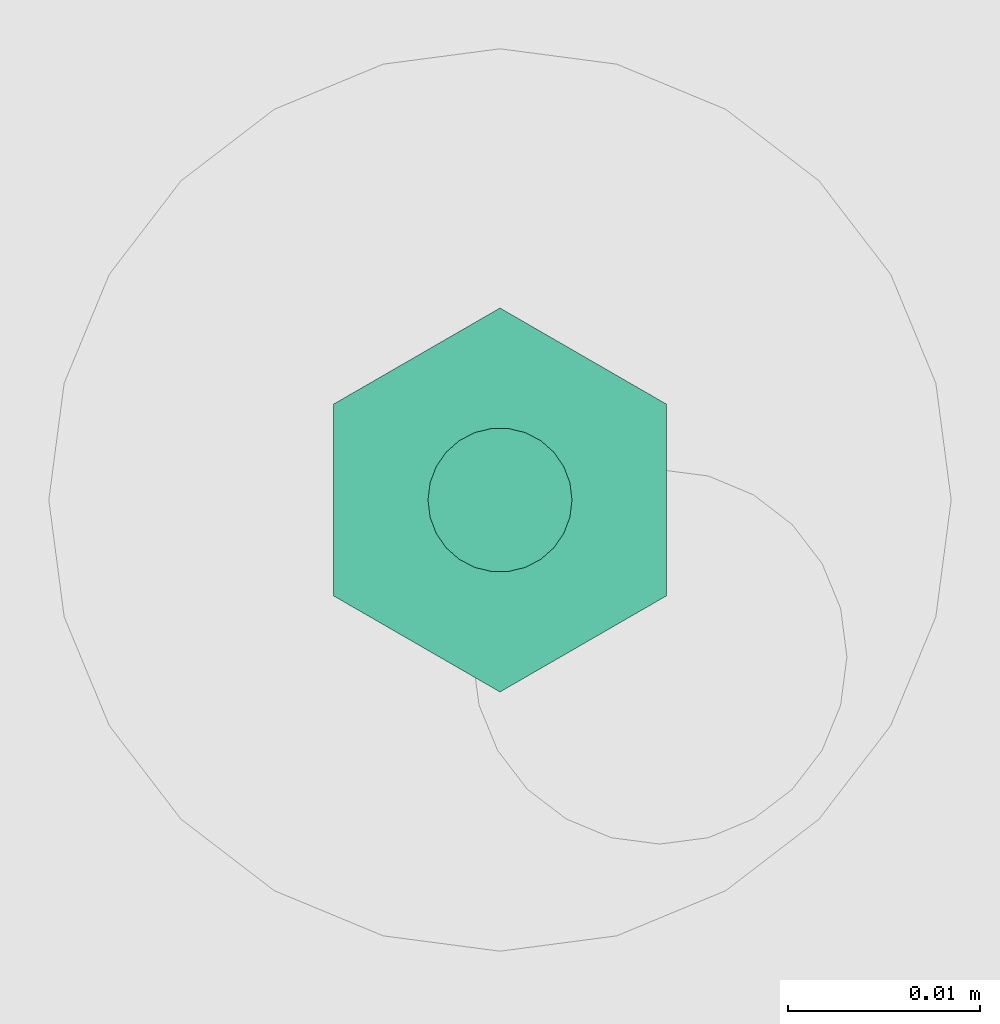
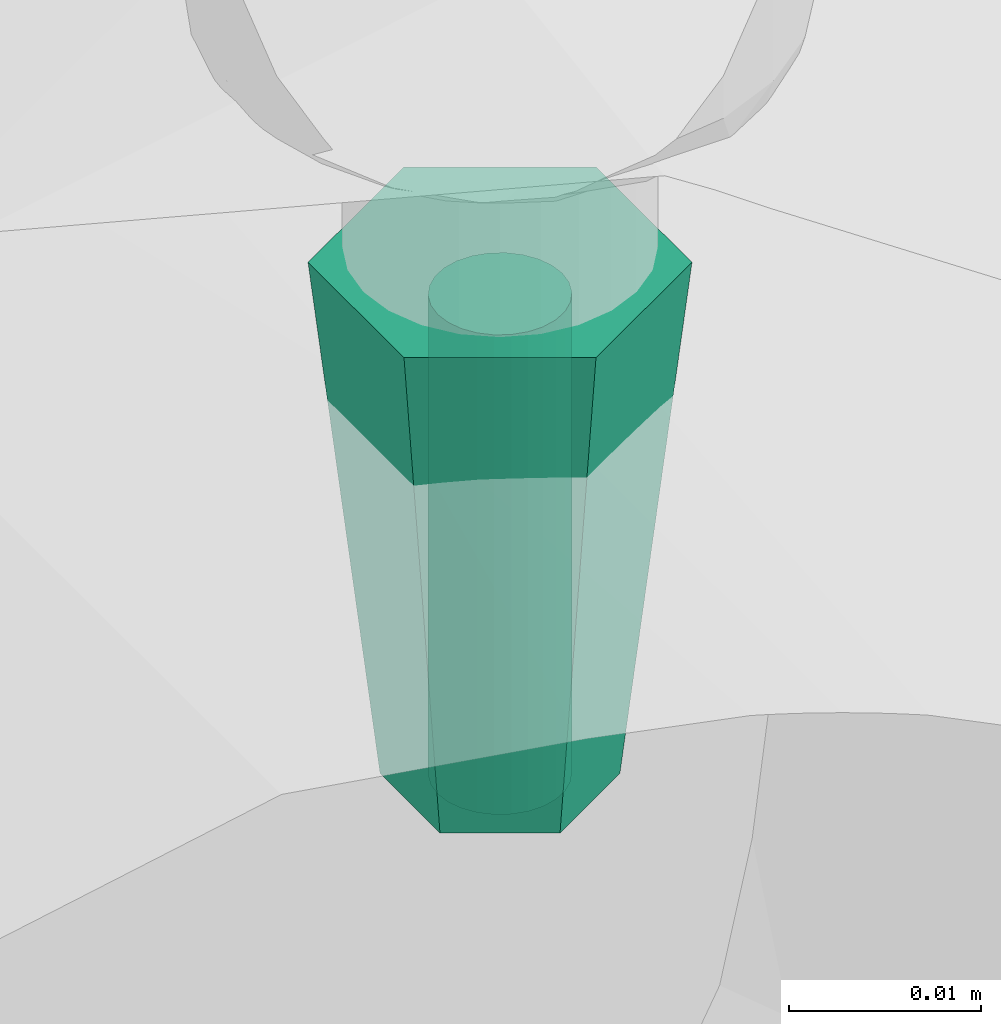
# One storey, part 5 of 6: 1 flow fitting, 1 flow segment.
"""IFC2X3 building model written with IfcOpenShell, lengths in millimetres."""

import ifcopenshell
import ifcopenshell.guid

model = None  # the IFC model being written
_history = None  # IfcOwnerHistory: only IFC2X3 demands one
_inside = {}  # id of a spatial element -> (the spatial element, [elements in it])
_under = {}  # id of a project, library or spatial element -> (it, [spatial elements below it])
_declared = {}  # id of a project -> (the project, [libraries it declares])
_typed = {}  # id of a type object -> (the type object, [elements of that type])
_made_of = {}  # id of a material, layer set ... -> (it, [elements and type objects made of it])


def new_model(schema):
    """Start an empty IFC model of exactly this schema.

    Asked for "IFC4X3", IfcOpenShell would pick the latest addendum, in which some entities
    have other attributes; the version numbers below select the first issue.
    IFC2X3 requires an IfcOwnerHistory on every rooted entity: one is made here for all.
    """
    global model, _history
    if schema == "IFC4X3":
        model = ifcopenshell.file(schema_version=(4, 3, 0, 0))
    else:
        model = ifcopenshell.file(schema=schema)
    _inside.clear()
    _under.clear()
    _declared.clear()
    _typed.clear()
    _made_of.clear()
    _history = None
    if model.schema == "IFC2X3":
        org = make("IfcOrganization", Name="unknown")
        user = make(
            "IfcPersonAndOrganization",
            ThePerson=make("IfcPerson", FamilyName="unknown"),
            TheOrganization=org,
        )
        app = make(
            "IfcApplication",
            ApplicationDeveloper=org,
            Version="unknown",
            ApplicationFullName="unknown",
            ApplicationIdentifier="unknown",
        )
        _history = make(
            "IfcOwnerHistory",
            OwningUser=user,
            OwningApplication=app,
            ChangeAction="ADDED",
            CreationDate=0,
        )
    return model


def make(cls, **values):
    """One entity of the class cls with the attributes given. An attribute that is None is left unset."""
    return model.create_entity(
        cls, **{name: value for name, value in values.items() if value is not None}
    )


def entity(cls, *values):
    """Any entity or typed value of the class cls, its attributes in the order of the schema. None: left unset."""
    e = model.create_entity(cls)
    for i, value in enumerate(values):
        if value is not None:
            e[i] = value
    return e


def rooted(cls, **values):
    """An entity with a GlobalId (a new one), such as an element, a storey or a relation."""
    return make(cls, GlobalId=ifcopenshell.guid.new(), OwnerHistory=_history, **values)


def si_unit(unit_type, name, prefix=None):
    """IfcSIUnit, for example si_unit("LENGTHUNIT", "METRE", prefix="MILLI")."""
    return make("IfcSIUnit", UnitType=unit_type, Prefix=prefix, Name=name)


def converted_unit(unit_type, name, factor, base, dimensions=None, offset=None):
    """IfcConversionBasedUnit, such as the inch: factor (a typed value) times the base unit."""
    return make(
        "IfcConversionBasedUnit"
        if offset is None
        else "IfcConversionBasedUnitWithOffset",
        ConversionOffset=offset,
        Dimensions=None
        if dimensions is None
        else entity("IfcDimensionalExponents", *dimensions),
        UnitType=unit_type,
        Name=name,
        ConversionFactor=make(
            "IfcMeasureWithUnit", ValueComponent=factor, UnitComponent=base
        ),
    )


def derived_unit(unit_type, elements):
    """IfcDerivedUnit: a product of units, each with its exponent."""
    return make(
        "IfcDerivedUnit",
        Elements=[
            make("IfcDerivedUnitElement", Unit=unit, Exponent=power)
            for unit, power in elements
        ],
        UnitType=unit_type,
    )


def assignment(units):
    """IfcUnitAssignment: the units of a project."""
    return None if units is None else make("IfcUnitAssignment", Units=units)


def point(xyz):
    """IfcCartesianPoint."""
    return None if xyz is None else make("IfcCartesianPoint", Coordinates=xyz)


def direction(xyz):
    """IfcDirection."""
    return None if xyz is None else make("IfcDirection", DirectionRatios=xyz)


def frame(location, z_axis=None, x_axis=None):
    """IfcAxis2Placement3D, a coordinate frame: its origin and axes. An axis left out is left unset."""
    return make(
        "IfcAxis2Placement3D",
        Location=point(location),
        Axis=direction(z_axis),
        RefDirection=direction(x_axis),
    )


def frame_2d(location, x_axis=None):
    """IfcAxis2Placement2D, a coordinate frame in the plane: its origin and x axis."""
    return make(
        "IfcAxis2Placement2D", Location=point(location), RefDirection=direction(x_axis)
    )


def origin():
    """The frame at (0, 0, 0) with its axes left unset."""
    return frame((0.0, 0.0, 0.0))


def origin_2d_with_axis():
    """The frame at (0, 0) in the plane with the x axis (1, 0) written out."""
    return frame_2d((0.0, 0.0), x_axis=(1.0, 0.0))


def place(relative_to, where):
    """IfcLocalPlacement: puts the frame where relative to a parent placement (None: the world)."""
    return make(
        "IfcLocalPlacement", PlacementRelTo=relative_to, RelativePlacement=where
    )


def context(
    kind, dimensions, precision=None, world=None, true_north=None, identifier=None
):
    """IfcGeometricRepresentationContext, for example the 3D "Model" context."""
    return make(
        "IfcGeometricRepresentationContext",
        ContextIdentifier=identifier,
        ContextType=kind,
        CoordinateSpaceDimension=dimensions,
        Precision=precision,
        WorldCoordinateSystem=world,
        TrueNorth=true_north,
    )


def subcontext(parent, identifier, kind, view, scale=None):
    """IfcGeometricRepresentationSubContext, for example "Body" below "Model"."""
    return make(
        "IfcGeometricRepresentationSubContext",
        ContextIdentifier=identifier,
        ContextType=kind,
        ParentContext=parent,
        TargetScale=scale,
        TargetView=view,
    )


def project(units=None, contexts=None):
    """IfcProject with its units and contexts."""
    return rooted(
        "IfcProject",
        Name="project",
        RepresentationContexts=contexts,
        UnitsInContext=assignment(units),
    )


def spatial(cls, under=None, at=None, **own):
    """A site, building, storey or space (cls), placed at a placement, below another one or the project."""
    s = rooted(cls, ObjectPlacement=at, **own)
    if under is not None:
        _under.setdefault(under.id(), (under, []))[1].append(s)
    return s


def profile(cls, at=None, kind="AREA", **sizes):
    """A parametric profile (cls). Its sizes go by their IFC names, for example OverallWidth=200.0."""
    return make(cls, ProfileType=kind, Position=at, **sizes)


def circle(**sizes):
    """IfcCircleProfileDef."""
    return profile("IfcCircleProfileDef", **sizes)


def extrude(swept, where, along, depth):
    """IfcExtrudedAreaSolid: the profile swept, set in the frame where, extruded along a direction by depth."""
    return make(
        "IfcExtrudedAreaSolid",
        SweptArea=swept,
        Position=where,
        ExtrudedDirection=direction(along),
        Depth=depth,
    )


def faces_of(points, faces, orient=None, outer=None):
    """IfcFace entities. A face is a list of loops; a loop is a list of indices into points, from 0.

    orient and outer hold one flag for each loop. By default every Orientation is true, the
    first loop of a face is its IfcFaceOuterBound and the others are IfcFaceBound.
    """
    made = []
    for i, loops in enumerate(faces):
        bounds = []
        for j, loop in enumerate(loops):
            is_outer = j == 0 if outer is None else outer[i][j]
            bounds.append(
                make(
                    "IfcFaceOuterBound" if is_outer else "IfcFaceBound",
                    Bound=make("IfcPolyLoop", Polygon=[points[k] for k in loop]),
                    Orientation=True if orient is None else orient[i][j],
                )
            )
        made.append(make("IfcFace", Bounds=bounds))
    return made


def faceted_brep(points, faces, orient=None, outer=None, voids=None):
    """IfcFacetedBrep: a solid bounded by flat faces; with voids (closed shells), ...WithVoids."""
    shared = [point(p) for p in points]
    hull = make("IfcClosedShell", CfsFaces=faces_of(shared, faces, orient, outer))
    if voids is None:
        return make("IfcFacetedBrep", Outer=hull)
    return make(
        "IfcFacetedBrepWithVoids",
        Outer=hull,
        Voids=[
            make(cls, CfsFaces=faces_of(shared, fs, o, b)) for cls, fs, o, b in voids
        ],
    )


def shape(context_of_items, identifier, shape_type, items):
    """IfcShapeRepresentation: the items that make up one representation, for example the "Body"."""
    return make(
        "IfcShapeRepresentation",
        ContextOfItems=context_of_items,
        RepresentationIdentifier=identifier,
        RepresentationType=shape_type,
        Items=items,
    )


def source(mapping_origin, context_of_items, identifier, shape_type, items):
    """IfcRepresentationMap: a shape defined once, which mapped items show again and again."""
    return make(
        "IfcRepresentationMap",
        MappingOrigin=mapping_origin,
        MappedRepresentation=shape(context_of_items, identifier, shape_type, items),
    )


def transform(
    local_origin,
    x_axis=None,
    y_axis=None,
    z_axis=None,
    scale=None,
    scale2=None,
    scale3=None,
    uniform=True,
):
    """IfcCartesianTransformationOperator3D, or its non-uniform kind. x_axis, y_axis, z_axis: its Axis1, 2, 3."""
    if uniform:
        return make(
            "IfcCartesianTransformationOperator3D",
            Axis1=direction(x_axis),
            Axis2=direction(y_axis),
            LocalOrigin=point(local_origin),
            Scale=scale,
            Axis3=direction(z_axis),
        )
    return make(
        "IfcCartesianTransformationOperator3DnonUniform",
        Axis1=direction(x_axis),
        Axis2=direction(y_axis),
        LocalOrigin=point(local_origin),
        Scale=scale,
        Axis3=direction(z_axis),
        Scale2=scale2,
        Scale3=scale3,
    )


def mapped(mapping_source, mapping_target):
    """IfcMappedItem: shows the shape of a source again, moved by a transform."""
    return make(
        "IfcMappedItem", MappingSource=mapping_source, MappingTarget=mapping_target
    )


def material(Name=None, Category=None):
    """IfcMaterial."""
    return make("IfcMaterial", Name=Name, Category=Category)


def made_of(thing, what):
    """Note that an element or type object is made of a material, layer set ...; save() writes the relation."""
    if what is not None:
        _made_of.setdefault(what.id(), (what, []))[1].append(thing)
    return thing


def type_object(cls, material=None, **own):
    """A type object (cls), such as IfcWallType, which elements share."""
    return made_of(rooted(cls, **own), material)


def type_shapes(of_type, sources):
    """Give a type object the sources (RepresentationMaps) that its elements show as mapped items."""
    of_type.RepresentationMaps = sources


def element(
    cls,
    number,
    at=None,
    inside=None,
    cuts=None,
    type_object=None,
    material=None,
    context=None,
    identifier="Body",
    shape_type=None,
    held_by="IfcProductDefinitionShape",
    body=None,
    shapes=None,
    **own,
):
    """One element of the class cls, such as IfcWall. Its Tag is "e" and its number.

    at: its placement. inside: the storey or other place that contains it. cuts: it is an
    opening in that element (IfcRelVoidsElement). A single representation is given by context,
    identifier, shape_type and body (its items); several are given by shapes. held_by: the class
    of the entity that holds the representations. save() writes the other relations.
    """
    e = rooted(cls, Tag="e%d" % number, ObjectPlacement=at, **own)
    if body is not None:
        shapes = [shape(context, identifier, shape_type, body)]
    if shapes is not None:
        e.Representation = make(held_by, Representations=shapes)
    if inside is not None:
        _inside.setdefault(inside.id(), (inside, []))[1].append(e)
    if cuts is not None:
        rooted(
            "IfcRelVoidsElement", RelatingBuildingElement=cuts, RelatedOpeningElement=e
        )
    if type_object is not None:
        _typed.setdefault(type_object.id(), (type_object, []))[1].append(e)
    return made_of(e, material)


def aggregate(whole, parts):
    """IfcRelAggregates: a whole, such as a stair, and the parts it consists of."""
    return rooted("IfcRelAggregates", RelatingObject=whole, RelatedObjects=parts)


def save(model, path):
    """Write the relations noted so far, then the file.

    IfcRelAggregates (storeys below a building ...), IfcRelContainedInSpatialStructure (elements
    in a storey), IfcRelDefinesByType, IfcRelAssociatesMaterial and IfcRelDeclares: one each for
    every whole, place, type object, material and project.
    """
    for whole, parts in _under.values():
        aggregate(whole, parts)
    for where, things in _inside.values():
        rooted(
            "IfcRelContainedInSpatialStructure",
            RelatedElements=things,
            RelatingStructure=where,
        )
    for kind, things in _typed.values():
        rooted("IfcRelDefinesByType", RelatedObjects=things, RelatingType=kind)
    for what, things in _made_of.values():
        rooted("IfcRelAssociatesMaterial", RelatedObjects=things, RelatingMaterial=what)
    for by, libraries in _declared.values():
        rooted("IfcRelDeclares", RelatingContext=by, RelatedDefinitions=libraries)
    model.write(path)


model = new_model("IFC2X3")

# Units and contexts
model_context = context("Model", 3, precision=0.01, world=origin(), true_north=direction((6.12303176911189e-17, 1.0)))
body_context = subcontext(model_context, "Body", "Model", "MODEL_VIEW")
ifc_project = project(units=[si_unit("LENGTHUNIT", "METRE", prefix="MILLI"), si_unit("AREAUNIT", "SQUARE_METRE"), si_unit("VOLUMEUNIT", "CUBIC_METRE"), converted_unit("PLANEANGLEUNIT", "DEGREE", entity("IfcRatioMeasure", 0.0174532925199433), si_unit("PLANEANGLEUNIT", "RADIAN"), dimensions=[0, 0, 0, 0, 0, 0, 0]), si_unit("MASSUNIT", "GRAM", prefix="KILO"), derived_unit("MASSDENSITYUNIT", [(si_unit("MASSUNIT", "GRAM", prefix="KILO"), 1), (si_unit("LENGTHUNIT", "METRE"), -3)]), derived_unit("MOMENTOFINERTIAUNIT", [(si_unit("LENGTHUNIT", "METRE"), 4)]), si_unit("TIMEUNIT", "SECOND"), si_unit("FREQUENCYUNIT", "HERTZ"), si_unit("THERMODYNAMICTEMPERATUREUNIT", "DEGREE_CELSIUS"), derived_unit("THERMALTRANSMITTANCEUNIT", [(si_unit("MASSUNIT", "GRAM", prefix="KILO"), 1), (si_unit("THERMODYNAMICTEMPERATUREUNIT", "KELVIN"), -1), (si_unit("TIMEUNIT", "SECOND"), -3)]), derived_unit("VOLUMETRICFLOWRATEUNIT", [(si_unit("LENGTHUNIT", "METRE"), 3), (si_unit("TIMEUNIT", "SECOND"), -1)]), derived_unit("MASSFLOWRATEUNIT", [(si_unit("MASSUNIT", "GRAM", prefix="KILO"), 1), (si_unit("TIMEUNIT", "SECOND"), -1)]), derived_unit("ROTATIONALFREQUENCYUNIT", [(si_unit("TIMEUNIT", "SECOND"), -1)]), si_unit("ELECTRICCURRENTUNIT", "AMPERE"), si_unit("ELECTRICVOLTAGEUNIT", "VOLT"), si_unit("POWERUNIT", "WATT"), si_unit("FORCEUNIT", "NEWTON", prefix="KILO"), si_unit("ILLUMINANCEUNIT", "LUX"), si_unit("LUMINOUSFLUXUNIT", "LUMEN"), si_unit("LUMINOUSINTENSITYUNIT", "CANDELA"), derived_unit("USERDEFINED", [(si_unit("MASSUNIT", "GRAM", prefix="KILO"), -1), (si_unit("LENGTHUNIT", "METRE"), -2), (si_unit("TIMEUNIT", "SECOND"), 3), (si_unit("LUMINOUSFLUXUNIT", "LUMEN"), 1)]), derived_unit("LINEARVELOCITYUNIT", [(si_unit("LENGTHUNIT", "METRE"), 1), (si_unit("TIMEUNIT", "SECOND"), -1)]), si_unit("PRESSUREUNIT", "PASCAL"), derived_unit("USERDEFINED", [(si_unit("LENGTHUNIT", "METRE"), -2), (si_unit("MASSUNIT", "GRAM", prefix="KILO"), 1), (si_unit("TIMEUNIT", "SECOND"), -2)]), derived_unit("LINEARFORCEUNIT", [(si_unit("MASSUNIT", "GRAM", prefix="KILO"), 1), (si_unit("LENGTHUNIT", "METRE"), 1), (si_unit("TIMEUNIT", "SECOND"), -2), (si_unit("LENGTHUNIT", "METRE"), -1)]), derived_unit("PLANARFORCEUNIT", [(si_unit("MASSUNIT", "GRAM", prefix="KILO"), 1), (si_unit("LENGTHUNIT", "METRE"), 1), (si_unit("TIMEUNIT", "SECOND"), -2), (si_unit("LENGTHUNIT", "METRE"), -2)])], contexts=[model_context])

# Site, building, storey
site_placement = place(None, origin())
site = spatial("IfcSite", under=ifc_project, at=site_placement, CompositionType="ELEMENT")
building_placement = place(site_placement, origin())
building = spatial("IfcBuilding", under=site, at=building_placement, CompositionType="ELEMENT")
storey_placement = place(building_placement, origin())
storey = spatial("IfcBuildingStorey", under=building, at=storey_placement, Name="01", CompositionType="ELEMENT", Elevation=0.0)

# Flow segment
pipe_segment_type = type_object("IfcPipeSegmentType", PredefinedType="NOTDEFINED")
flow_segment_placement = place(storey_placement, frame((31074.65, 10416.98, 31077.0)))
element("IfcFlowSegment", 1, at=flow_segment_placement, inside=storey, type_object=pipe_segment_type, context=body_context, shape_type="SweptSolid", body=[
    extrude(circle(Radius=3.75, at=origin_2d_with_axis()), frame((5.35, 5.35, 0.0), z_axis=(6.64719940030807e-08, 0.0, 1.0), x_axis=(-1.0, 0.0, 6.64719940030807e-08)), (0.0, 0.0, 1.0), 30.5000000000105),
])

# Flow fitting
ifc_material = material()
pipe_fitting_type = type_object("IfcPipeFittingType", Name="ADSK_2", PredefinedType="NOTDEFINED", material=ifc_material)
shared_shape = source(origin(), body_context, "Body", "Brep", [
    faceted_brep([(32.5, 3.12, 5.41), (32.5, -3.13, 5.41), (32.5, -6.25, 0.0), (32.5, -3.13, -5.41), (32.5, 3.12, -5.41), (32.5, 6.25, 0.0), (0.0, 5.0, 8.66), (0.0, 10.0, 0.0), (0.0, 5.0, -8.66), (0.0, -5.0, -8.66), (0.0, -10.0, 0.0), (0.0, -5.0, 8.66)], [[[0, 1, 2, 3, 4, 5]], [[6, 7, 8, 9, 10, 11]], [[5, 4, 8, 7]], [[4, 3, 9, 8]], [[3, 2, 10, 9]], [[2, 1, 11, 10]], [[1, 0, 6, 11]], [[0, 5, 7, 6]]]),
])
type_shapes(pipe_fitting_type, [shared_shape])
flow_fitting_placement = place(storey_placement, frame((31080.0, 10422.33, 31109.5), z_axis=(-1.0, 0.0, -1.01369679116909e-07), x_axis=(1.01369679116909e-07, 0.0, -1.0)))
element("IfcFlowFitting", 2, at=flow_fitting_placement, inside=storey, type_object=pipe_fitting_type, material=ifc_material, Name="ADSK_2", ObjectType="ADSK_2", context=body_context, shape_type="MappedRepresentation", body=[
    mapped(shared_shape, transform((0.0, 0.0, 0.0), scale=1.0)),
])

save(model, "model.ifc")
